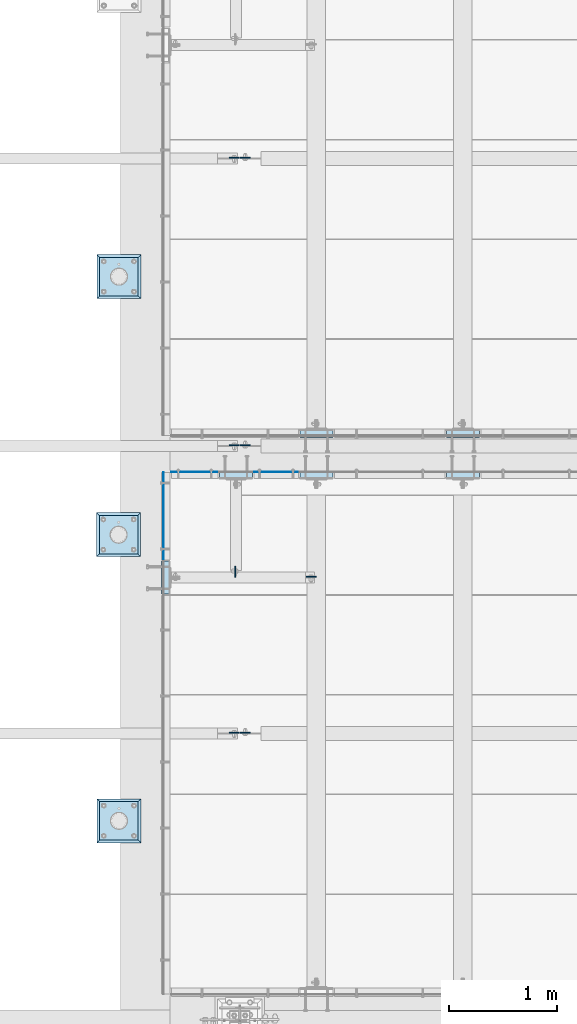
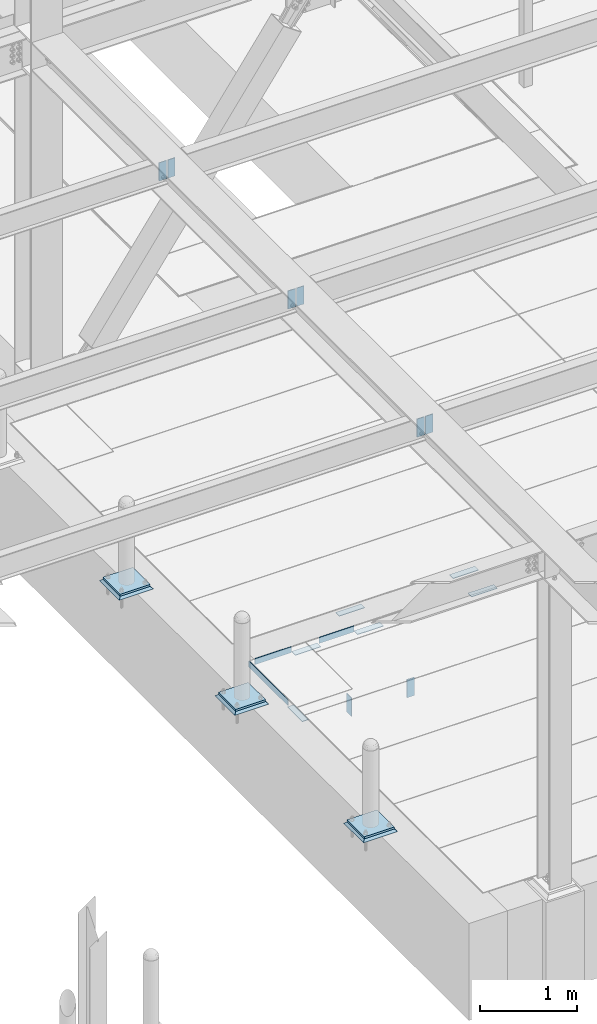
# One storey, part 3016 of 3843: 23 plates, 18 elements without a shape of their own.
"""IFC2X3 building model written with IfcOpenShell, lengths in millimetres."""

import ifcopenshell
import ifcopenshell.guid

model = None  # the IFC model being written
_history = None  # IfcOwnerHistory: only IFC2X3 demands one
_inside = {}  # id of a spatial element -> (the spatial element, [elements in it])
_under = {}  # id of a project, library or spatial element -> (it, [spatial elements below it])
_declared = {}  # id of a project -> (the project, [libraries it declares])
_typed = {}  # id of a type object -> (the type object, [elements of that type])
_made_of = {}  # id of a material, layer set ... -> (it, [elements and type objects made of it])


def new_model(schema):
    """Start an empty IFC model of exactly this schema.

    Asked for "IFC4X3", IfcOpenShell would pick the latest addendum, in which some entities
    have other attributes; the version numbers below select the first issue.
    IFC2X3 requires an IfcOwnerHistory on every rooted entity: one is made here for all.
    """
    global model, _history
    if schema == "IFC4X3":
        model = ifcopenshell.file(schema_version=(4, 3, 0, 0))
    else:
        model = ifcopenshell.file(schema=schema)
    _inside.clear()
    _under.clear()
    _declared.clear()
    _typed.clear()
    _made_of.clear()
    _history = None
    if model.schema == "IFC2X3":
        org = make("IfcOrganization", Name="unknown")
        user = make(
            "IfcPersonAndOrganization",
            ThePerson=make("IfcPerson", FamilyName="unknown"),
            TheOrganization=org,
        )
        app = make(
            "IfcApplication",
            ApplicationDeveloper=org,
            Version="unknown",
            ApplicationFullName="unknown",
            ApplicationIdentifier="unknown",
        )
        _history = make(
            "IfcOwnerHistory",
            OwningUser=user,
            OwningApplication=app,
            ChangeAction="ADDED",
            CreationDate=0,
        )
    return model


def make(cls, **values):
    """One entity of the class cls with the attributes given. An attribute that is None is left unset."""
    return model.create_entity(
        cls, **{name: value for name, value in values.items() if value is not None}
    )


def rooted(cls, **values):
    """An entity with a GlobalId (a new one), such as an element, a storey or a relation."""
    return make(cls, GlobalId=ifcopenshell.guid.new(), OwnerHistory=_history, **values)


def si_unit(unit_type, name, prefix=None):
    """IfcSIUnit, for example si_unit("LENGTHUNIT", "METRE", prefix="MILLI")."""
    return make("IfcSIUnit", UnitType=unit_type, Prefix=prefix, Name=name)


def assignment(units):
    """IfcUnitAssignment: the units of a project."""
    return None if units is None else make("IfcUnitAssignment", Units=units)


def point(xyz):
    """IfcCartesianPoint."""
    return None if xyz is None else make("IfcCartesianPoint", Coordinates=xyz)


def direction(xyz):
    """IfcDirection."""
    return None if xyz is None else make("IfcDirection", DirectionRatios=xyz)


def frame(location, z_axis=None, x_axis=None):
    """IfcAxis2Placement3D, a coordinate frame: its origin and axes. An axis left out is left unset."""
    return make(
        "IfcAxis2Placement3D",
        Location=point(location),
        Axis=direction(z_axis),
        RefDirection=direction(x_axis),
    )


def origin_with_axes():
    """The frame at (0, 0, 0) with the z axis (0, 0, 1) and the x axis (1, 0, 0) written out."""
    return frame((0.0, 0.0, 0.0), z_axis=(0.0, 0.0, 1.0), x_axis=(1.0, 0.0, 0.0))


def place(relative_to, where):
    """IfcLocalPlacement: puts the frame where relative to a parent placement (None: the world)."""
    return make(
        "IfcLocalPlacement", PlacementRelTo=relative_to, RelativePlacement=where
    )


def context(
    kind, dimensions, precision=None, world=None, true_north=None, identifier=None
):
    """IfcGeometricRepresentationContext, for example the 3D "Model" context."""
    return make(
        "IfcGeometricRepresentationContext",
        ContextIdentifier=identifier,
        ContextType=kind,
        CoordinateSpaceDimension=dimensions,
        Precision=precision,
        WorldCoordinateSystem=world,
        TrueNorth=true_north,
    )


def subcontext(parent, identifier, kind, view, scale=None):
    """IfcGeometricRepresentationSubContext, for example "Body" below "Model"."""
    return make(
        "IfcGeometricRepresentationSubContext",
        ContextIdentifier=identifier,
        ContextType=kind,
        ParentContext=parent,
        TargetScale=scale,
        TargetView=view,
    )


def project(units=None, contexts=None):
    """IfcProject with its units and contexts."""
    return rooted(
        "IfcProject",
        Name="project",
        RepresentationContexts=contexts,
        UnitsInContext=assignment(units),
    )


def spatial(cls, under=None, at=None, **own):
    """A site, building, storey or space (cls), placed at a placement, below another one or the project."""
    s = rooted(cls, ObjectPlacement=at, **own)
    if under is not None:
        _under.setdefault(under.id(), (under, []))[1].append(s)
    return s


def faces_of(points, faces, orient=None, outer=None):
    """IfcFace entities. A face is a list of loops; a loop is a list of indices into points, from 0.

    orient and outer hold one flag for each loop. By default every Orientation is true, the
    first loop of a face is its IfcFaceOuterBound and the others are IfcFaceBound.
    """
    made = []
    for i, loops in enumerate(faces):
        bounds = []
        for j, loop in enumerate(loops):
            is_outer = j == 0 if outer is None else outer[i][j]
            bounds.append(
                make(
                    "IfcFaceOuterBound" if is_outer else "IfcFaceBound",
                    Bound=make("IfcPolyLoop", Polygon=[points[k] for k in loop]),
                    Orientation=True if orient is None else orient[i][j],
                )
            )
        made.append(make("IfcFace", Bounds=bounds))
    return made


def faceted_brep(points, faces, orient=None, outer=None, voids=None):
    """IfcFacetedBrep: a solid bounded by flat faces; with voids (closed shells), ...WithVoids."""
    shared = [point(p) for p in points]
    hull = make("IfcClosedShell", CfsFaces=faces_of(shared, faces, orient, outer))
    if voids is None:
        return make("IfcFacetedBrep", Outer=hull)
    return make(
        "IfcFacetedBrepWithVoids",
        Outer=hull,
        Voids=[
            make(cls, CfsFaces=faces_of(shared, fs, o, b)) for cls, fs, o, b in voids
        ],
    )


def shape(context_of_items, identifier, shape_type, items):
    """IfcShapeRepresentation: the items that make up one representation, for example the "Body"."""
    return make(
        "IfcShapeRepresentation",
        ContextOfItems=context_of_items,
        RepresentationIdentifier=identifier,
        RepresentationType=shape_type,
        Items=items,
    )


def material(Name=None, Category=None):
    """IfcMaterial."""
    return make("IfcMaterial", Name=Name, Category=Category)


def made_of(thing, what):
    """Note that an element or type object is made of a material, layer set ...; save() writes the relation."""
    if what is not None:
        _made_of.setdefault(what.id(), (what, []))[1].append(thing)
    return thing


def type_object(cls, material=None, **own):
    """A type object (cls), such as IfcWallType, which elements share."""
    return made_of(rooted(cls, **own), material)


def element(
    cls,
    number,
    at=None,
    inside=None,
    cuts=None,
    type_object=None,
    material=None,
    context=None,
    identifier="Body",
    shape_type=None,
    held_by="IfcProductDefinitionShape",
    body=None,
    shapes=None,
    **own,
):
    """One element of the class cls, such as IfcWall. Its Tag is "e" and its number.

    at: its placement. inside: the storey or other place that contains it. cuts: it is an
    opening in that element (IfcRelVoidsElement). A single representation is given by context,
    identifier, shape_type and body (its items); several are given by shapes. held_by: the class
    of the entity that holds the representations. save() writes the other relations.
    """
    e = rooted(cls, Tag="e%d" % number, ObjectPlacement=at, **own)
    if body is not None:
        shapes = [shape(context, identifier, shape_type, body)]
    if shapes is not None:
        e.Representation = make(held_by, Representations=shapes)
    if inside is not None:
        _inside.setdefault(inside.id(), (inside, []))[1].append(e)
    if cuts is not None:
        rooted(
            "IfcRelVoidsElement", RelatingBuildingElement=cuts, RelatedOpeningElement=e
        )
    if type_object is not None:
        _typed.setdefault(type_object.id(), (type_object, []))[1].append(e)
    return made_of(e, material)


def aggregate(whole, parts):
    """IfcRelAggregates: a whole, such as a stair, and the parts it consists of."""
    return rooted("IfcRelAggregates", RelatingObject=whole, RelatedObjects=parts)


def save(model, path):
    """Write the relations noted so far, then the file.

    IfcRelAggregates (storeys below a building ...), IfcRelContainedInSpatialStructure (elements
    in a storey), IfcRelDefinesByType, IfcRelAssociatesMaterial and IfcRelDeclares: one each for
    every whole, place, type object, material and project.
    """
    for whole, parts in _under.values():
        aggregate(whole, parts)
    for where, things in _inside.values():
        rooted(
            "IfcRelContainedInSpatialStructure",
            RelatedElements=things,
            RelatingStructure=where,
        )
    for kind, things in _typed.values():
        rooted("IfcRelDefinesByType", RelatedObjects=things, RelatingType=kind)
    for what, things in _made_of.values():
        rooted("IfcRelAssociatesMaterial", RelatedObjects=things, RelatingMaterial=what)
    for by, libraries in _declared.values():
        rooted("IfcRelDeclares", RelatingContext=by, RelatedDefinitions=libraries)
    model.write(path)


model = new_model("IFC2X3")

# Units and contexts
model_context = context("Model", 3, precision=1e-05, world=origin_with_axes())
body_context = subcontext(model_context, "Body", "Model", "MODEL_VIEW")
ifc_project = project(units=[si_unit("LENGTHUNIT", "METRE", prefix="MILLI"), si_unit("AREAUNIT", "SQUARE_METRE"), si_unit("VOLUMEUNIT", "CUBIC_METRE"), si_unit("MASSUNIT", "GRAM", prefix="KILO"), si_unit("TIMEUNIT", "SECOND"), si_unit("PLANEANGLEUNIT", "RADIAN"), si_unit("SOLIDANGLEUNIT", "STERADIAN"), si_unit("THERMODYNAMICTEMPERATUREUNIT", "DEGREE_CELSIUS"), si_unit("LUMINOUSINTENSITYUNIT", "LUMEN")], contexts=[model_context])

# Site, building, storey
site_placement = place(None, origin_with_axes())
site = spatial("IfcSite", under=ifc_project, at=site_placement, CompositionType="ELEMENT")
building_placement = place(site_placement, origin_with_axes())
building = spatial("IfcBuilding", under=site, at=building_placement, Name="Undefined", CompositionType="ELEMENT")
storey_placement = place(building_placement, origin_with_axes())
storey = spatial("IfcBuildingStorey", under=building, at=storey_placement, Name="Undefined", CompositionType="ELEMENT", Elevation=0.0)

# Assembly, plate
assembly_1_placement = place(storey_placement, origin_with_axes())
assembly_1 = element("IfcElementAssembly", 1, at=assembly_1_placement, inside=storey, Name="EMBED PLATE", AssemblyPlace="NOTDEFINED", PredefinedType="RIGID_FRAME")
ifc_material_1 = material(Name="STEEL/A36")
plate_type_1 = type_object("IfcPlateType", PredefinedType="NOTDEFINED")
plate_1_placement = place(assembly_1_placement, frame((41417.8750030518, 19243.675, 30400.625), z_axis=(0.0, -1.0, 0.0), x_axis=(-1.0, 0.0, 0.0)))
plate_1 = element("IfcPlate", 2, at=plate_1_placement, type_object=plate_type_1, material=ifc_material_1, Name="PLATE", context=body_context, shape_type="Brep", body=[
    faceted_brep([(0.0, -3.17499999999927, 0.0), (0.0, -3.17499999999927, 304.800000000003), (0.0, 3.17499999999927, 304.800000000003), (0.0, 3.17499999999927, 0.0), (76.1999999999971, -3.17499999999927, 304.799999999996), (76.1999999999971, 3.17499999999927, 304.799999999996), (76.1999999999971, -3.17499999999927, 0.0), (76.1999999999971, 3.17499999999927, 0.0)], [[[0, 1, 2, 3]], [[1, 4, 5, 2]], [[4, 6, 7, 5]], [[6, 0, 3, 7]], [[5, 7, 3, 2]], [[6, 4, 1, 0]]]),
])
aggregate(assembly_1, [plate_1])

assembly_2_placement = place(storey_placement, origin_with_axes())
assembly_2 = element("IfcElementAssembly", 3, at=assembly_2_placement, inside=storey, Name="EMBED PLATE", AssemblyPlace="NOTDEFINED", PredefinedType="RIGID_FRAME")
plate_2_placement = place(assembly_2_placement, frame((42179.875, 20005.6749969482, 30400.625), z_axis=(-1.0, 0.0, 0.0), x_axis=(0.0, 1.0, 0.0)))
plate_2 = element("IfcPlate", 4, at=plate_2_placement, type_object=plate_type_1, material=ifc_material_1, Name="PLATE", context=body_context, shape_type="Brep", body=[
    faceted_brep([(0.0, -3.17499999999927, 0.0), (0.0, -3.17499999999927, 304.800000000003), (0.0, 3.17499999999927, 304.800000000003), (0.0, 3.17499999999927, 0.0), (76.1999999999971, -3.17499999999927, 304.799999999996), (76.1999999999971, 3.17499999999927, 304.799999999996), (76.1999999999971, -3.17499999999927, 0.0), (76.1999999999971, 3.17499999999927, 0.0)], [[[0, 1, 2, 3]], [[1, 4, 5, 2]], [[4, 6, 7, 5]], [[6, 0, 3, 7]], [[5, 7, 3, 2]], [[6, 4, 1, 0]]]),
])
aggregate(assembly_2, [plate_2])

assembly_3_placement = place(storey_placement, origin_with_axes())
assembly_3 = element("IfcElementAssembly", 5, at=assembly_3_placement, inside=storey, Name="EMBED PLATE", AssemblyPlace="NOTDEFINED", PredefinedType="RIGID_FRAME")
plate_3_placement = place(assembly_3_placement, frame((42922.825, 20005.6749969482, 30400.625), z_axis=(-1.0, 0.0, 0.0), x_axis=(0.0, 1.0, 0.0)))
plate_3 = element("IfcPlate", 6, at=plate_3_placement, type_object=plate_type_1, material=ifc_material_1, Name="PLATE", context=body_context, shape_type="Brep", body=[
    faceted_brep([(0.0, -3.17499999999927, 0.0), (0.0, -3.17499999999927, 304.800000000003), (0.0, 3.17499999999927, 304.800000000003), (0.0, 3.17499999999927, 0.0), (76.1999999999971, -3.17499999999927, 304.799999999996), (76.1999999999971, 3.17499999999927, 304.799999999996), (76.1999999999971, -3.17499999999927, 0.0), (76.1999999999971, 3.17499999999927, 0.0)], [[[0, 1, 2, 3]], [[1, 4, 5, 2]], [[4, 6, 7, 5]], [[6, 0, 3, 7]], [[5, 7, 3, 2]], [[6, 4, 1, 0]]]),
])
aggregate(assembly_3, [plate_3])

assembly_4_placement = place(storey_placement, origin_with_axes())
assembly_4 = element("IfcElementAssembly", 7, at=assembly_4_placement, inside=storey, Name="EMBED PLATE", AssemblyPlace="NOTDEFINED", PredefinedType="RIGID_FRAME")
plate_4_placement = place(assembly_4_placement, frame((44275.375, 20005.6749969482, 30400.625), z_axis=(-1.0, 0.0, 0.0), x_axis=(0.0, 1.0, 0.0)))
plate_4 = element("IfcPlate", 8, at=plate_4_placement, type_object=plate_type_1, material=ifc_material_1, Name="PLATE", context=body_context, shape_type="Brep", body=[
    faceted_brep([(0.0, -3.17499999999927, 0.0), (0.0, -3.17499999999927, 304.800000000003), (0.0, 3.17499999999927, 304.800000000003), (0.0, 3.17499999999927, 0.0), (76.1999999999971, -3.17499999999927, 304.799999999996), (76.1999999999971, 3.17499999999927, 304.799999999996), (76.1999999999971, -3.17499999999927, 0.0), (76.1999999999971, 3.17499999999927, 0.0)], [[[0, 1, 2, 3]], [[1, 4, 5, 2]], [[4, 6, 7, 5]], [[6, 0, 3, 7]], [[5, 7, 3, 2]], [[6, 4, 1, 0]]]),
])
aggregate(assembly_4, [plate_4])

assembly_5_placement = place(storey_placement, origin_with_axes())
assembly_5 = element("IfcElementAssembly", 9, at=assembly_5_placement, inside=storey, Name="EMBED PLATE", AssemblyPlace="NOTDEFINED", PredefinedType="RIGID_FRAME")
plate_5_placement = place(assembly_5_placement, frame((43970.575, 20462.8750030517, 30400.625), z_axis=(1.0, 0.0, 0.0), x_axis=(0.0, -1.0, 0.0)))
plate_5 = element("IfcPlate", 10, at=plate_5_placement, type_object=plate_type_1, material=ifc_material_1, Name="PLATE", context=body_context, shape_type="Brep", body=[
    faceted_brep([(0.0, -3.17499999999927, 0.0), (0.0, -3.17499999999927, 304.800000000003), (0.0, 3.17499999999927, 304.800000000003), (0.0, 3.17499999999927, 0.0), (76.1999999999971, -3.17499999999927, 304.799999999996), (76.1999999999971, 3.17499999999927, 304.799999999996), (76.1999999999971, -3.17499999999927, 0.0), (76.1999999999971, 3.17499999999927, 0.0)], [[[0, 1, 2, 3]], [[1, 4, 5, 2]], [[4, 6, 7, 5]], [[6, 0, 3, 7]], [[5, 7, 3, 2]], [[6, 4, 1, 0]]]),
])
aggregate(assembly_5, [plate_5])

assembly_6_placement = place(storey_placement, origin_with_axes())
assembly_6 = element("IfcElementAssembly", 11, at=assembly_6_placement, inside=storey, Name="EMBED PLATE", AssemblyPlace="NOTDEFINED", PredefinedType="RIGID_FRAME")
plate_6_placement = place(assembly_6_placement, frame((42618.025, 20462.8750030518, 30400.625), z_axis=(1.0, 0.0, 0.0), x_axis=(0.0, -1.0, 0.0)))
plate_6 = element("IfcPlate", 12, at=plate_6_placement, type_object=plate_type_1, material=ifc_material_1, Name="PLATE", context=body_context, shape_type="Brep", body=[
    faceted_brep([(0.0, -3.17499999999927, 0.0), (0.0, -3.17499999999927, 304.800000000003), (0.0, 3.17499999999927, 304.800000000003), (0.0, 3.17499999999927, 0.0), (76.1999999999971, -3.17499999999927, 304.799999999996), (76.1999999999971, 3.17499999999927, 304.799999999996), (76.1999999999971, -3.17499999999927, 0.0), (76.1999999999971, 3.17499999999927, 0.0)], [[[0, 1, 2, 3]], [[1, 4, 5, 2]], [[4, 6, 7, 5]], [[6, 0, 3, 7]], [[5, 7, 3, 2]], [[6, 4, 1, 0]]]),
])
aggregate(assembly_6, [plate_6])

assembly_7_placement = place(storey_placement, origin_with_axes())
assembly_7 = element("IfcElementAssembly", 13, at=assembly_7_placement, inside=storey, Name="ANGLE", AssemblyPlace="NOTDEFINED", PredefinedType="RIGID_FRAME")
plate_7_placement = place(assembly_7_placement, frame((42192.5750014866, 20066.0000051248, 30403.8000030518), z_axis=(1.0, 0.0, 0.0), x_axis=(0.0, 0.0, 1.0)))
plate_7 = element("IfcPlate", 14, at=plate_7_placement, type_object=plate_type_1, material=ifc_material_1, Name="PLATE", context=body_context, shape_type="Brep", body=[
    faceted_brep([(0.0, -3.17499999999927, 0.0), (-1.00761426438112e-05, -3.17499999982101, 412.750012208846), (-1.00761426438112e-05, 3.17500000018481, 412.750012208831), (0.0, 3.17499999999927, 0.0), (76.1999892724925, -3.17499999981919, 412.750012209093), (76.1999892724925, 3.17500000018481, 412.750012209079), (76.1999999999971, -3.17499999999927, 0.0), (76.1999999999971, 3.17499999999927, 0.0)], [[[0, 1, 2, 3]], [[1, 4, 5, 2]], [[4, 6, 7, 5]], [[6, 0, 3, 7]], [[5, 7, 3, 2]], [[6, 4, 1, 0]]]),
])
aggregate(assembly_7, [plate_7])

assembly_8_placement = place(storey_placement, origin_with_axes())
assembly_8 = element("IfcElementAssembly", 15, at=assembly_8_placement, inside=storey, Name="ANGLE", AssemblyPlace="NOTDEFINED", PredefinedType="RIGID_FRAME")
plate_8_placement = place(assembly_8_placement, frame((41430.5750012962, 20066.0000074091, 30403.8000030518), z_axis=(1.0, 0.0, 0.0), x_axis=(0.0, 0.0, 1.0)))
plate_8 = element("IfcPlate", 16, at=plate_8_placement, type_object=plate_type_1, material=ifc_material_1, Name="PLATE", context=body_context, shape_type="Brep", body=[
    faceted_brep([(0.0, -3.17499999999927, 0.0), (-1.03997081168927e-05, -3.17499999999927, 431.799987792969), (-1.03997081168927e-05, 3.17499999999927, 431.799987792969), (0.0, 3.17499999999927, 0.0), (76.1999893189823, -3.17499999999927, 431.799987793223), (76.1999893189823, 3.17499999999927, 431.799987793223), (76.1999999999971, -3.17499999999927, 0.0), (76.1999999999971, 3.17499999999927, 0.0)], [[[0, 1, 2, 3]], [[1, 4, 5, 2]], [[4, 6, 7, 5]], [[6, 0, 3, 7]], [[5, 7, 3, 2]], [[6, 4, 1, 0]]]),
])
aggregate(assembly_8, [plate_8])

assembly_9_placement = place(storey_placement, origin_with_axes())
assembly_9 = element("IfcElementAssembly", 17, at=assembly_9_placement, inside=storey, Name="ANGLE", AssemblyPlace="NOTDEFINED", PredefinedType="RIGID_FRAME")
plate_9_placement = place(assembly_9_placement, frame((41357.5500030518, 19256.3747863229, 30403.8000030518), z_axis=(0.0, 0.999999999997942, -2.02899998962774e-06), x_axis=(0.0, 2.02899999567308e-06, 0.999999999997942)))
plate_9 = element("IfcPlate", 18, at=plate_9_placement, type_object=plate_type_1, material=ifc_material_1, Name="PLATE", context=body_context, shape_type="Brep", body=[
    faceted_brep([(0.0, -3.17499999999927, 0.0), (0.00108199702663114, -3.17500000000291, 806.450036627399), (0.00108199702663114, 3.17500000000291, 806.450036627399), (0.0, 3.17499999999927, 0.0), (76.2010812158915, -3.17500000000291, 806.449975592201), (76.2010812158915, 3.17500000000291, 806.449975592201), (76.1999999999971, -3.17499999999927, 0.0), (76.1999999999971, 3.17499999999927, 0.0)], [[[0, 1, 2, 3]], [[1, 4, 5, 2]], [[4, 6, 7, 5]], [[6, 0, 3, 7]], [[5, 7, 3, 2]], [[6, 4, 1, 0]]]),
])
aggregate(assembly_9, [plate_9])

assembly_10_placement = place(storey_placement, origin_with_axes())
assembly_10 = element("IfcElementAssembly", 19, at=assembly_10_placement, inside=storey, Name="PIPE_BOLLARD", AssemblyPlace="NOTDEFINED", PredefinedType="RIGID_FRAME")
ifc_material_2 = material(Name="STEEL/A572-50")
plate_type_2 = type_object("IfcPlateType", PredefinedType="NOTDEFINED")
plate_10_placement = place(assembly_10_placement, frame((40769.4793884277, 21693.2622637535, 30518.1), z_axis=(0.0, 1.0, 0.0), x_axis=(1.0, 0.0, 0.0)))
plate_10 = element("IfcPlate", 20, at=plate_10_placement, type_object=plate_type_2, material=ifc_material_2, Name="PLATE", context=body_context, shape_type="Brep", body=[
    faceted_brep([(0.0, -12.6999999999971, 0.0), (0.0, -12.7000000000007, 355.600000000006), (0.0, 12.7000000000007, 355.600000000006), (0.0, 12.6999999999971, 0.0), (355.599999999999, -12.7000000000007, 355.600000000006), (355.599999999999, 12.7000000000007, 355.600000000006), (355.599999999999, -12.7000000000007, 0.0), (355.599999999999, 12.7000000000007, 0.0)], [[[0, 1, 2, 3]], [[1, 4, 5, 2]], [[4, 6, 7, 5]], [[6, 0, 3, 7]], [[5, 7, 3, 2]], [[6, 4, 1, 0]]]),
])
aggregate(assembly_10, [plate_10])

assembly_11_placement = place(storey_placement, origin_with_axes())
assembly_11 = element("IfcElementAssembly", 21, at=assembly_11_placement, inside=storey, Name="PIPE_BOLLARD", AssemblyPlace="NOTDEFINED", PredefinedType="RIGID_FRAME")
plate_11_placement = place(assembly_11_placement, frame((40765.878314209, 19310.5527605797, 30518.1), z_axis=(0.0, 1.0, 0.0), x_axis=(1.0, 0.0, 0.0)))
plate_11 = element("IfcPlate", 22, at=plate_11_placement, type_object=plate_type_2, material=ifc_material_2, Name="PLATE", context=body_context, shape_type="Brep", body=[
    faceted_brep([(0.0, -12.6999999999971, 0.0), (0.0, -12.7000000000007, 355.600000000006), (0.0, 12.7000000000007, 355.600000000006), (0.0, 12.6999999999971, 0.0), (355.599999999999, -12.7000000000007, 355.600000000006), (355.599999999999, 12.7000000000007, 355.600000000006), (355.599999999999, -12.7000000000007, 0.0), (355.599999999999, 12.7000000000007, 0.0)], [[[0, 1, 2, 3]], [[1, 4, 5, 2]], [[4, 6, 7, 5]], [[6, 0, 3, 7]], [[5, 7, 3, 2]], [[6, 4, 1, 0]]]),
])
aggregate(assembly_11, [plate_11])

assembly_12_placement = place(storey_placement, origin_with_axes())
assembly_12 = element("IfcElementAssembly", 23, at=assembly_12_placement, inside=storey, Name="PIPE_BOLLARD", AssemblyPlace="NOTDEFINED", PredefinedType="RIGID_FRAME")
plate_12_placement = place(assembly_12_placement, frame((40769.4793884277, 16668.9092364098, 30518.1), z_axis=(0.0, 1.0, 0.0), x_axis=(1.0, 0.0, 0.0)))
plate_12 = element("IfcPlate", 24, at=plate_12_placement, type_object=plate_type_2, material=ifc_material_2, Name="PLATE", context=body_context, shape_type="Brep", body=[
    faceted_brep([(0.0, -12.6999999999971, 0.0), (0.0, -12.7000000000007, 355.600000000006), (0.0, 12.7000000000007, 355.600000000006), (0.0, 12.6999999999971, 0.0), (355.599999999999, -12.7000000000007, 355.600000000006), (355.599999999999, 12.7000000000007, 355.600000000006), (355.599999999999, -12.7000000000007, 0.0), (355.599999999999, 12.7000000000007, 0.0)], [[[0, 1, 2, 3]], [[1, 4, 5, 2]], [[4, 6, 7, 5]], [[6, 0, 3, 7]], [[5, 7, 3, 2]], [[6, 4, 1, 0]]]),
])
aggregate(assembly_12, [plate_12])

assembly_13_placement = place(storey_placement, origin_with_axes())
assembly_13 = element("IfcElementAssembly", 25, at=assembly_13_placement, inside=storey, Name="GROUT", AssemblyPlace="NOTDEFINED", PredefinedType="REINFORCEMENT_UNIT")
ifc_material_3 = material(Name="CONCRETE/Concrete_Undefined")
plate_type_3 = type_object("IfcPlateType", PredefinedType="NOTDEFINED")
plate_13_placement = place(assembly_13_placement, frame((40744.0793884277, 21667.8622637535, 30492.7), z_axis=(0.0, 1.0, 0.0), x_axis=(1.0, 0.0, 0.0)))
plate_13 = element("IfcPlate", 26, at=plate_13_placement, type_object=plate_type_3, material=ifc_material_3, Name="GROUT", context=body_context, shape_type="Brep", body=[
    faceted_brep([(25.4000000001906, -12.6999999998552, 380.999999999505), (0.0, 12.7000000000007, 406.399999999994), (0.0, 12.6999999999971, 0.0), (25.4000000001906, -12.6999999999898, 25.4000000004453), (380.999999999833, -12.6999999998588, 25.4000000004453), (406.400000000001, 12.7000000000007, 0.0), (406.400000000001, 12.7000000000007, 406.399999999994), (380.999999999833, -12.6999999999898, 380.999999999505)], [[[0, 1, 2, 3]], [[4, 5, 6, 7]], [[4, 7, 0, 3]], [[5, 4, 3, 2]], [[6, 5, 2, 1]], [[7, 6, 1, 0]]]),
])
aggregate(assembly_13, [plate_13])

assembly_14_placement = place(storey_placement, origin_with_axes())
assembly_14 = element("IfcElementAssembly", 27, at=assembly_14_placement, inside=storey, Name="GROUT", AssemblyPlace="NOTDEFINED", PredefinedType="REINFORCEMENT_UNIT")
plate_14_placement = place(assembly_14_placement, frame((40740.478314209, 19285.1527605797, 30492.7), z_axis=(0.0, 1.0, 0.0), x_axis=(1.0, 0.0, 0.0)))
plate_14 = element("IfcPlate", 28, at=plate_14_placement, type_object=plate_type_3, material=ifc_material_3, Name="GROUT", context=body_context, shape_type="Brep", body=[
    faceted_brep([(25.4000000001906, -12.6999999998552, 380.999999999505), (0.0, 12.7000000000007, 406.399999999994), (0.0, 12.6999999999971, 0.0), (25.4000000001906, -12.6999999999898, 25.4000000004453), (380.999999999833, -12.6999999998588, 25.4000000004453), (406.400000000001, 12.7000000000007, 0.0), (406.400000000001, 12.7000000000007, 406.399999999994), (380.999999999833, -12.6999999999898, 380.999999999505)], [[[0, 1, 2, 3]], [[4, 5, 6, 7]], [[4, 7, 0, 3]], [[5, 4, 3, 2]], [[6, 5, 2, 1]], [[7, 6, 1, 0]]]),
])
aggregate(assembly_14, [plate_14])

assembly_15_placement = place(storey_placement, origin_with_axes())
assembly_15 = element("IfcElementAssembly", 29, at=assembly_15_placement, inside=storey, Name="GROUT", AssemblyPlace="NOTDEFINED", PredefinedType="REINFORCEMENT_UNIT")
plate_15_placement = place(assembly_15_placement, frame((40744.0793884277, 16643.5092364098, 30492.7), z_axis=(0.0, 1.0, 0.0), x_axis=(1.0, 0.0, 0.0)))
plate_15 = element("IfcPlate", 30, at=plate_15_placement, type_object=plate_type_3, material=ifc_material_3, Name="GROUT", context=body_context, shape_type="Brep", body=[
    faceted_brep([(25.4000000001906, -12.6999999998552, 380.999999999505), (0.0, 12.7000000000007, 406.399999999994), (0.0, 12.6999999999971, 0.0), (25.4000000001906, -12.6999999999898, 25.4000000004453), (380.999999999833, -12.6999999998588, 25.4000000004453), (406.400000000001, 12.7000000000007, 0.0), (406.400000000001, 12.7000000000007, 406.399999999994), (380.999999999833, -12.6999999999898, 380.999999999505)], [[[0, 1, 2, 3]], [[4, 5, 6, 7]], [[4, 7, 0, 3]], [[5, 4, 3, 2]], [[6, 5, 2, 1]], [[7, 6, 1, 0]]]),
])
aggregate(assembly_15, [plate_15])

assembly_16_placement = place(storey_placement, origin_with_axes())
assembly_16 = element("IfcElementAssembly", 31, at=assembly_16_placement, inside=storey, Name="BEAM", AssemblyPlace="NOTDEFINED", PredefinedType="RIGID_FRAME")
plate_type_4 = type_object("IfcPlateType", PredefinedType="NOTDEFINED")
plate_16_placement = place(assembly_16_placement, frame((42766.45625, 19099.2125, 30365.7), z_axis=(-1.0, 0.0, 0.0), x_axis=(0.0, 0.0, -1.0)))
plate_16 = element("IfcPlate", 32, at=plate_16_placement, type_object=plate_type_4, material=ifc_material_2, Name="PLATE", context=body_context, shape_type="Brep", body=[
    faceted_brep([(0.0, -4.76249999999709, 0.0), (0.0, -4.76249999999709, 88.9000015258789), (0.0, 4.76249999999709, 88.9000015258789), (0.0, 4.76249999999709, 0.0), (228.600006102781, -4.7625000004191, 88.9000015257589), (228.600006102781, 4.76249999954598, 88.9000015257443), (228.600006103079, -4.7625000004482, 7.27595761418343e-12), (228.600006103079, 4.76249999954598, -7.27595761418343e-12)], [[[0, 1, 2, 3]], [[1, 4, 5, 2]], [[4, 6, 7, 5]], [[6, 0, 3, 7]], [[5, 7, 3, 2]], [[6, 4, 1, 0]]]),
])
aggregate(assembly_16, [plate_16])

# Assembly, plates
assembly_17_placement = place(storey_placement, origin_with_axes())
assembly_17 = element("IfcElementAssembly", 33, at=assembly_17_placement, inside=storey, Name="BEAM", AssemblyPlace="NOTDEFINED", PredefinedType="RIGID_FRAME")
plate_17_placement = place(assembly_17_placement, frame((42068.75, 17660.9375, 34759.9), z_axis=(1.0, 0.0, 0.0), x_axis=(0.0, 0.0, -1.0)))
plate_17 = element("IfcPlate", 34, at=plate_17_placement, type_object=plate_type_4, material=ifc_material_2, Name="PLATE", context=body_context, shape_type="Brep", body=[
    faceted_brep([(0.0, -4.76249999999709, 0.0), (0.0, -4.76249999999709, 88.9000015258789), (0.0, 4.76249999999709, 88.9000015258789), (0.0, 4.76249999999709, 0.0), (228.600006102781, -4.7625000004191, 88.9000015257589), (228.600006102781, 4.76249999954598, 88.9000015257443), (228.600006103079, -4.7625000004482, 7.27595761418343e-12), (228.600006103079, 4.76249999954598, -7.27595761418343e-12)], [[[0, 1, 2, 3]], [[1, 4, 5, 2]], [[4, 6, 7, 5]], [[6, 0, 3, 7]], [[5, 7, 3, 2]], [[6, 4, 1, 0]]]),
])
plate_18_placement = place(assembly_17_placement, frame((42068.75, 20315.2375, 34759.9), z_axis=(1.0, 0.0, 0.0), x_axis=(0.0, 0.0, -1.0)))
plate_18 = element("IfcPlate", 35, at=plate_18_placement, type_object=plate_type_4, material=ifc_material_2, Name="PLATE", context=body_context, shape_type="Brep", body=[
    faceted_brep([(0.0, -4.76249999999709, 0.0), (0.0, -4.76249999999709, 88.9000015258789), (0.0, 4.76249999999709, 88.9000015258789), (0.0, 4.76249999999709, 0.0), (228.600006102781, -4.7625000004191, 88.9000015257589), (228.600006102781, 4.76249999954598, 88.9000015257443), (228.600006103079, -4.7625000004482, 7.27595761418343e-12), (228.600006103079, 4.76249999954598, -7.27595761418343e-12)], [[[0, 1, 2, 3]], [[1, 4, 5, 2]], [[4, 6, 7, 5]], [[6, 0, 3, 7]], [[5, 7, 3, 2]], [[6, 4, 1, 0]]]),
])
plate_19_placement = place(assembly_17_placement, frame((42056.05, 17660.9375, 34759.9), z_axis=(-1.0, 0.0, 0.0), x_axis=(0.0, 0.0, -1.0)))
plate_19 = element("IfcPlate", 36, at=plate_19_placement, type_object=plate_type_4, material=ifc_material_2, Name="PLATE", context=body_context, shape_type="Brep", body=[
    faceted_brep([(0.0, -4.76249999999709, 0.0), (0.0, -4.76249999999709, 88.9000015258789), (0.0, 4.76249999999709, 88.9000015258789), (0.0, 4.76249999999709, 0.0), (228.600006102781, -4.7625000004191, 88.9000015257589), (228.600006102781, 4.76249999954598, 88.9000015257443), (228.600006103079, -4.7625000004482, 7.27595761418343e-12), (228.600006103079, 4.76249999954598, -7.27595761418343e-12)], [[[0, 1, 2, 3]], [[1, 4, 5, 2]], [[4, 6, 7, 5]], [[6, 0, 3, 7]], [[5, 7, 3, 2]], [[6, 4, 1, 0]]]),
])
plate_20_placement = place(assembly_17_placement, frame((42056.05, 20315.2375, 34759.9), z_axis=(-1.0, 0.0, 0.0), x_axis=(0.0, 0.0, -1.0)))
plate_20 = element("IfcPlate", 37, at=plate_20_placement, type_object=plate_type_4, material=ifc_material_2, Name="PLATE", context=body_context, shape_type="Brep", body=[
    faceted_brep([(0.0, -4.76249999999709, 0.0), (0.0, -4.76249999999709, 88.9000015258789), (0.0, 4.76249999999709, 88.9000015258789), (0.0, 4.76249999999709, 0.0), (228.600006102781, -4.7625000004191, 88.9000015257589), (228.600006102781, 4.76249999954598, 88.9000015257443), (228.600006103079, -4.7625000004482, 7.27595761418343e-12), (228.600006103079, 4.76249999954598, -7.27595761418343e-12)], [[[0, 1, 2, 3]], [[1, 4, 5, 2]], [[4, 6, 7, 5]], [[6, 0, 3, 7]], [[5, 7, 3, 2]], [[6, 4, 1, 0]]]),
])
plate_21_placement = place(assembly_17_placement, frame((42068.75, 22969.5375, 34759.9), z_axis=(1.0, 0.0, 0.0), x_axis=(0.0, 0.0, -1.0)))
plate_21 = element("IfcPlate", 38, at=plate_21_placement, type_object=plate_type_4, material=ifc_material_2, Name="PLATE", context=body_context, shape_type="Brep", body=[
    faceted_brep([(0.0, -4.76249999999709, 0.0), (0.0, -4.76249999999709, 88.9000015258789), (0.0, 4.76249999999709, 88.9000015258789), (0.0, 4.76249999999709, 0.0), (228.600006102781, -4.7625000004191, 88.9000015257589), (228.600006102781, 4.76249999954598, 88.9000015257443), (228.600006103079, -4.7625000004482, 7.27595761418343e-12), (228.600006103079, 4.76249999954598, -7.27595761418343e-12)], [[[0, 1, 2, 3]], [[1, 4, 5, 2]], [[4, 6, 7, 5]], [[6, 0, 3, 7]], [[5, 7, 3, 2]], [[6, 4, 1, 0]]]),
])
plate_22_placement = place(assembly_17_placement, frame((42056.05, 22969.5375, 34759.9), z_axis=(-1.0, 0.0, 0.0), x_axis=(0.0, 0.0, -1.0)))
plate_22 = element("IfcPlate", 39, at=plate_22_placement, type_object=plate_type_4, material=ifc_material_2, Name="PLATE", context=body_context, shape_type="Brep", body=[
    faceted_brep([(0.0, -4.76249999999709, 0.0), (0.0, -4.76249999999709, 88.9000015258789), (0.0, 4.76249999999709, 88.9000015258789), (0.0, 4.76249999999709, 0.0), (228.600006102781, -4.7625000004191, 88.9000015257589), (228.600006102781, 4.76249999954598, 88.9000015257443), (228.600006103079, -4.7625000004482, 7.27595761418343e-12), (228.600006103079, 4.76249999954598, -7.27595761418343e-12)], [[[0, 1, 2, 3]], [[1, 4, 5, 2]], [[4, 6, 7, 5]], [[6, 0, 3, 7]], [[5, 7, 3, 2]], [[6, 4, 1, 0]]]),
])
aggregate(assembly_17, [plate_17, plate_18, plate_19, plate_20, plate_21, plate_22])

# Assembly, plate
assembly_18_placement = place(storey_placement, origin_with_axes())
assembly_18 = element("IfcElementAssembly", 40, at=assembly_18_placement, inside=storey, Name="BEAM", AssemblyPlace="NOTDEFINED", PredefinedType="RIGID_FRAME")
plate_type_5 = type_object("IfcPlateType", PredefinedType="NOTDEFINED")
plate_23_placement = place(assembly_18_placement, frame((42019.5375, 19094.45, 30365.7), z_axis=(0.0, 1.0, 0.0), x_axis=(0.0, 0.0, -1.0)))
plate_23 = element("IfcPlate", 41, at=plate_23_placement, type_object=plate_type_5, material=ifc_material_2, Name="PLATE", context=body_context, shape_type="Brep", body=[
    faceted_brep([(0.0, -4.76249999999709, 0.0), (0.0, -4.76249999999709, 101.599999999999), (0.0, 4.76249999999709, 101.599999999999), (0.0, 4.76249999999709, 0.0), (228.600006103516, -4.76249999999709, 101.599998474121), (228.600006103516, 4.76249999999709, 101.599998474121), (228.600006103079, -4.7625000004482, 7.27595761418343e-12), (228.600006103079, 4.76249999954598, -7.27595761418343e-12)], [[[0, 1, 2, 3]], [[1, 4, 5, 2]], [[4, 6, 7, 5]], [[6, 0, 3, 7]], [[5, 7, 3, 2]], [[6, 4, 1, 0]]]),
])
aggregate(assembly_18, [plate_23])

save(model, "model.ifc")
